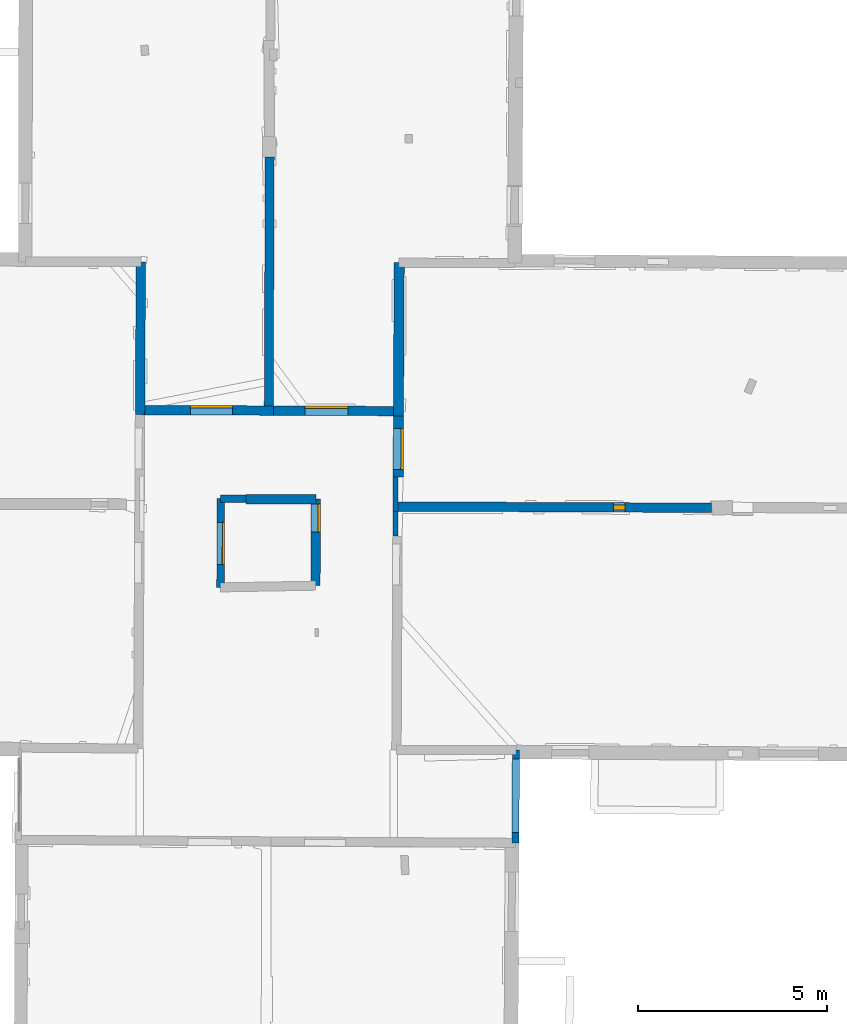
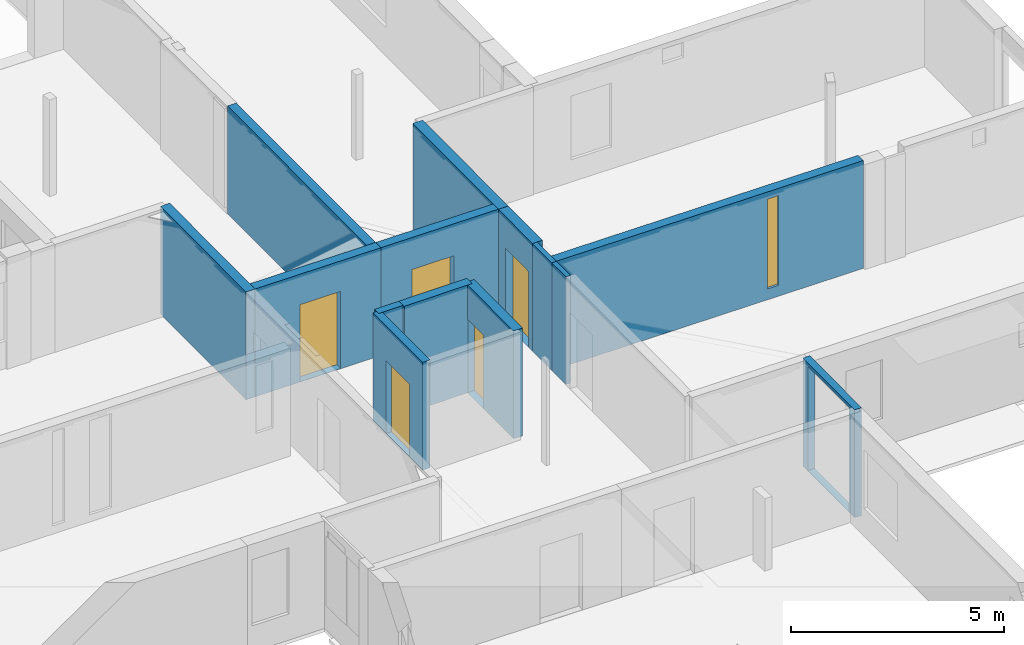
# One storey, part 10 of 17: 14 walls, 5 doors, 1 window, 7 openings.
"""IFC2X3 building model written with IfcOpenShell, lengths in metres."""

from ifc_helpers import new_model, entity, si_unit, converted_unit, derived_unit, direction, frame, frame_2d, origin, origin_2d_with_axis, place, context, subcontext, project, spatial, polyline, rectangle, outline, extrude, clip, halfspace, source, transform, mapped, material, layer, layer_set, layer_usage, type_object, type_shapes, element, fill, save


model = new_model("IFC2X3")

# Units and contexts
model_context = context("Model", 3, precision=1e-05, world=origin(), true_north=direction((0.0, 1.0)))
body_context = subcontext(model_context, "Body", "Model", "MODEL_VIEW")
ifc_project = project(units=[si_unit("LENGTHUNIT", "METRE"), si_unit("AREAUNIT", "SQUARE_METRE"), si_unit("VOLUMEUNIT", "CUBIC_METRE"), converted_unit("PLANEANGLEUNIT", "DEGREE", entity("IfcRatioMeasure", 0.0174532925199433), si_unit("PLANEANGLEUNIT", "RADIAN"), dimensions=[0, 0, 0, 0, 0, 0, 0]), si_unit("MASSUNIT", "GRAM", prefix="KILO"), derived_unit("MASSDENSITYUNIT", [(si_unit("MASSUNIT", "GRAM", prefix="KILO"), 1), (si_unit("LENGTHUNIT", "METRE"), -3)]), derived_unit("MOMENTOFINERTIAUNIT", [(si_unit("LENGTHUNIT", "METRE"), 4)]), si_unit("TIMEUNIT", "SECOND"), si_unit("FREQUENCYUNIT", "HERTZ"), si_unit("THERMODYNAMICTEMPERATUREUNIT", "DEGREE_CELSIUS"), derived_unit("THERMALTRANSMITTANCEUNIT", [(si_unit("MASSUNIT", "GRAM", prefix="KILO"), 1), (si_unit("THERMODYNAMICTEMPERATUREUNIT", "KELVIN"), -1), (si_unit("TIMEUNIT", "SECOND"), -3)]), derived_unit("VOLUMETRICFLOWRATEUNIT", [(si_unit("LENGTHUNIT", "METRE"), 3), (si_unit("TIMEUNIT", "SECOND"), -1)]), si_unit("ELECTRICCURRENTUNIT", "AMPERE"), si_unit("ELECTRICVOLTAGEUNIT", "VOLT"), si_unit("POWERUNIT", "WATT"), si_unit("FORCEUNIT", "NEWTON", prefix="KILO"), si_unit("ILLUMINANCEUNIT", "LUX"), si_unit("LUMINOUSFLUXUNIT", "LUMEN"), si_unit("LUMINOUSINTENSITYUNIT", "CANDELA"), derived_unit("USERDEFINED", [(si_unit("MASSUNIT", "GRAM", prefix="KILO"), -1), (si_unit("LENGTHUNIT", "METRE"), -2), (si_unit("TIMEUNIT", "SECOND"), 3), (si_unit("LUMINOUSFLUXUNIT", "LUMEN"), 1)]), derived_unit("LINEARVELOCITYUNIT", [(si_unit("LENGTHUNIT", "METRE"), 1), (si_unit("TIMEUNIT", "SECOND"), -1)]), si_unit("PRESSUREUNIT", "PASCAL"), derived_unit("USERDEFINED", [(si_unit("LENGTHUNIT", "METRE"), -2), (si_unit("MASSUNIT", "GRAM", prefix="KILO"), 1), (si_unit("TIMEUNIT", "SECOND"), -2)]), derived_unit("LINEARFORCEUNIT", [(si_unit("MASSUNIT", "GRAM", prefix="KILO"), 1), (si_unit("LENGTHUNIT", "METRE"), 1), (si_unit("TIMEUNIT", "SECOND"), -2), (si_unit("LENGTHUNIT", "METRE"), -1)]), derived_unit("PLANARFORCEUNIT", [(si_unit("MASSUNIT", "GRAM", prefix="KILO"), 1), (si_unit("LENGTHUNIT", "METRE"), 1), (si_unit("TIMEUNIT", "SECOND"), -2), (si_unit("LENGTHUNIT", "METRE"), -2)])], contexts=[model_context])

# Site, building, storey
placement = place(None, origin())
site = spatial("IfcSite", under=ifc_project, at=placement, CompositionType="ELEMENT")
building = spatial("IfcBuilding", under=site, at=placement, CompositionType="ELEMENT")
storey_placement = place(placement, frame((0.0, 0.0, 12.0782108306885)))
storey = spatial("IfcBuildingStorey", under=building, at=storey_placement, Name="Level 5", CompositionType="ELEMENT", Elevation=12.0782108306885)

# Wall, opening, door
ifc_material_1 = material(Name="Default wall")
ifc_layer_1 = layer(ifc_material_1, 0.25)
ifc_layer_set_1 = layer_set([ifc_layer_1], Name="wall_thickness_0.2500")
ifc_layer_usage_1 = layer_usage(ifc_layer_set_1, "AXIS2", "POSITIVE", -0.125)
wall_type_1 = type_object("IfcWallType", Name="wall_thickness_0.2500", PredefinedType="STANDARD", material=ifc_layer_set_1)
wall_1_placement = place(storey_placement, frame((2.9732673349329, 60.1694172213467, 0.0), z_axis=(0.0, 0.0, 1.0), x_axis=(0.999991078854273, -0.00422400424551604, 0.0)))
wall_1 = element("IfcWallStandardCase", 1, at=wall_1_placement, inside=storey, type_object=wall_type_1, material=ifc_layer_usage_1, Name="Wall:252", ObjectType="Wall", context=body_context, shape_type="Clipping", body=[
    clip(clip(extrude(outline(polyline([(3.52570150487162, -0.125), (3.52570150487162, 0.125), (0.0, 0.125), (0.0, -0.125), (3.52570150487162, -0.125)])), origin(), (0.0, 0.0, 1.0), 3.09134044647217), halfspace(frame((21.6645418552215, -2.57535797375986, 9.01350348246577), z_axis=(0.000828137503824083, 0.389454305620105, 0.921045415830423), x_axis=(-0.999992003356814, 0.00392608366811369, -0.000760979274747706)), False)), halfspace(frame((-4.30223903086172, 15.6563531810917, 5.79573318480268), z_axis=(-0.389900704445387, -0.000232514676882885, 0.920856876289642), x_axis=(0.920854522577645, -0.00165731940970147, 0.389902810378011)), False)),
])
opening_1_placement = place(wall_1_placement, frame((1.34075493354691, -0.125, 0.00578975677490234)))
opening_1 = element("IfcOpeningElement", 2, at=opening_1_placement, cuts=wall_1, Name="Opening : 1100 x 2215 : 226", ObjectType="Opening", context=body_context, shape_type="SweptSolid", body=[
    extrude(rectangle(XDim=1.1, YDim=2.215, at=frame_2d((1.1075, 0.55), x_axis=(0.0, 1.0))), frame((0.0, 0.0, 0.0), z_axis=(0.0, 1.0, 0.0), x_axis=(0.0, 0.0, 1.0)), (0.0, 0.0, 1.0), 0.25),
])
ifc_material_2 = material(Name="Door Panel")
door_style_1 = type_object("IfcDoorStyle", Name="Door : 1100 x 2215mm", ConstructionType="NOTDEFINED", OperationType="SINGLE_SWING_RIGHT", ParameterTakesPrecedence=False, Sizeable=False, material=ifc_material_2)
shared_shape_1 = source(origin(), body_context, "Body", "SweptSolid", [
    extrude(rectangle(XDim=0.0625, YDim=1.1, at=origin_2d_with_axis()), frame((0.55, 0.21875, 0.0), z_axis=(0.0, 0.0, 1.0), x_axis=(0.0, 1.0, 0.0)), (0.0, 0.0, 1.0), 2.215),
])
type_shapes(door_style_1, [shared_shape_1])
door_1_placement = place(opening_1_placement, origin())
door_1 = element("IfcDoor", 3, at=door_1_placement, inside=storey, type_object=door_style_1, Name="Door : 1100 x 2215mm : 38", ObjectType="Door : 1100 x 2215mm", OverallHeight=2.215, OverallWidth=1.1, context=body_context, shape_type="MappedRepresentation", body=[
    mapped(shared_shape_1, transform((0.0, 0.0, 0.0), scale=1.0)),
])
fill(opening_1, door_1)

wall_2_placement = place(storey_placement, frame((6.4989373865076, 60.1545246432217, 0.0), z_axis=(0.0, 0.0, 1.0), x_axis=(0.999991078140899, -0.0042241731265633, 0.0)))
wall_2 = element("IfcWallStandardCase", 4, at=wall_2_placement, inside=storey, type_object=wall_type_1, material=ifc_layer_usage_1, Name="Wall:253", ObjectType="Wall", context=body_context, shape_type="Clipping", body=[
    clip(clip(extrude(outline(polyline([(3.31243752352933, -0.125), (3.31243752352933, 0.125), (0.0, 0.125), (0.0, -0.125), (3.31243752352933, -0.125)])), origin(), (0.0, 0.0, 1.0), 3.09134044647217), halfspace(frame((18.1388407852826, -2.57535491042614, 9.01350348246577), z_axis=(0.000828071731786291, 0.389454305759958, 0.921045415830423), x_axis=(-0.999992004019847, 0.00392591478691017, -0.000760979274747706)), False)), halfspace(frame((6.24537303460496, 17.1086275764733, 6.35864093399329), z_axis=(0.390500039958128, -0.000254261316809501, 0.920602875372374), x_axis=(-0.680866467789572, -0.673140016301975, 0.288623234499112)), False)),
])
opening_2_placement = place(wall_2_placement, frame((0.845053493044792, -0.125, 0.00578975677490234)))
opening_2 = element("IfcOpeningElement", 5, at=opening_2_placement, cuts=wall_2, Name="Opening : 1135 x 2170 : 227", ObjectType="Opening", context=body_context, shape_type="SweptSolid", body=[
    extrude(rectangle(XDim=1.135, YDim=2.17, at=frame_2d((1.085, 0.5675), x_axis=(0.0, 1.0))), frame((0.0, 0.0, 0.0), z_axis=(0.0, 1.0, 0.0), x_axis=(0.0, 0.0, 1.0)), (0.0, 0.0, 1.0), 0.25),
])
door_style_2 = type_object("IfcDoorStyle", Name="Door : 1135 x 2170mm", ConstructionType="NOTDEFINED", OperationType="SINGLE_SWING_RIGHT", ParameterTakesPrecedence=False, Sizeable=False, material=ifc_material_2)
shared_shape_2 = source(origin(), body_context, "Body", "SweptSolid", [
    extrude(rectangle(XDim=0.0625, YDim=1.135, at=origin_2d_with_axis()), frame((0.5675, 0.21875, 0.0), z_axis=(0.0, 0.0, 1.0), x_axis=(0.0, 1.0, 0.0)), (0.0, 0.0, 1.0), 2.17),
])
type_shapes(door_style_2, [shared_shape_2])
door_2_placement = place(opening_2_placement, origin())
door_2 = element("IfcDoor", 6, at=door_2_placement, inside=storey, type_object=door_style_2, Name="Door : 1135 x 2170mm : 39", ObjectType="Door : 1135 x 2170mm", OverallHeight=2.17, OverallWidth=1.135, context=body_context, shape_type="MappedRepresentation", body=[
    mapped(shared_shape_2, transform((0.0, 0.0, 0.0), scale=1.0)),
])
fill(opening_2, door_2)

# Wall, opening, window
wall_3_placement = place(storey_placement, frame((9.73171064603028, 57.616053512142, 0.0), z_axis=(0.0, 0.0, 1.0), x_axis=(0.999991816075073, -0.00404571166512474, 0.0)))
wall_3 = element("IfcWallStandardCase", 7, at=wall_3_placement, inside=storey, type_object=wall_type_1, material=ifc_layer_usage_1, Name="Wall:260", ObjectType="Wall", context=body_context, shape_type="Clipping", body=[
    clip(clip(extrude(outline(polyline([(8.36634234952258, -0.125), (8.36634234952258, 0.125), (0.0, 0.125), (0.0, -0.125), (8.36634234952258, -0.125)])), origin(), (0.0, 0.0, 1.0), 3.09134044647217), halfspace(frame((14.8953641658864, -0.0532204931752561, 9.01350348246577), z_axis=(0.000897574897068893, 0.389454151777931, 0.921045415830423), x_axis=(-0.999991287464978, 0.00410437628379763, -0.000760979274747706)), False)), halfspace(frame((3.00540946690516, 19.6328842240395, 6.35864093399329), z_axis=(0.390499988363369, -0.000323951116077735, 0.920602875372374), x_axis=(-0.68098658752467, -0.673018496119368, 0.288623234499112)), False)),
])
opening_3_placement = place(wall_3_placement, frame((5.77032811993926, -0.125, 0.310789108276367)))
opening_3 = element("IfcOpeningElement", 8, at=opening_3_placement, cuts=wall_3, Name="Opening : 305 x 2575 : 228", ObjectType="Opening", context=body_context, shape_type="SweptSolid", body=[
    extrude(rectangle(XDim=0.305, YDim=2.575, at=frame_2d((1.2875, 0.1525), x_axis=(0.0, 1.0))), frame((0.0, 0.0, 0.0), z_axis=(0.0, 1.0, 0.0), x_axis=(0.0, 0.0, 1.0)), (0.0, 0.0, 1.0), 0.25),
])
ifc_material_3 = material(Name="Window Default")
window_style = type_object("IfcWindowStyle", Name="Window : 305 x 2575mm", ConstructionType="NOTDEFINED", OperationType="NOTDEFINED", ParameterTakesPrecedence=False, Sizeable=False, material=ifc_material_3)
shared_shape_3 = source(origin(), body_context, "Body", "SweptSolid", [
    extrude(rectangle(XDim=0.125, YDim=0.305, at=origin_2d_with_axis()), frame((0.1525, 0.125, 0.0), z_axis=(0.0, 0.0, 1.0), x_axis=(0.0, 1.0, 0.0)), (0.0, 0.0, 1.0), 2.575),
])
type_shapes(window_style, [shared_shape_3])
window_placement = place(opening_3_placement, origin())
window = element("IfcWindow", 9, at=window_placement, inside=storey, type_object=window_style, Name="Window : 305 x 2575mm : 123", ObjectType="Window : 305 x 2575mm", OverallHeight=2.575, OverallWidth=0.305, context=body_context, shape_type="MappedRepresentation", body=[
    mapped(shared_shape_3, transform((0.0, 0.0, 0.0), scale=1.0)),
])
fill(opening_3, window)

# Walls
wall_4_placement = place(storey_placement, frame((2.99464268628783, 64.0884731860502, 0.0), z_axis=(0.0, 0.0, 1.0), x_axis=(-0.00545393374022704, -0.999985127192778, 0.0)))
element("IfcWallStandardCase", 10, at=wall_4_placement, inside=storey, type_object=wall_type_1, material=ifc_layer_usage_1, Name="Wall:292", ObjectType="Wall", context=body_context, shape_type="Clipping", body=[
    clip(clip(extrude(outline(polyline([(4.04411608607963, -0.125), (4.04411608607963, 0.125), (0.0, 0.125), (0.0, -0.125), (4.04411608607963, -0.125)])), origin(), (0.0, 0.0, 1.0), 3.09134044647217), halfspace(frame((6.46782411694884, 21.6676922519037, 9.01350348246577), z_axis=(-0.389455029606745, 0.000349130022532686, 0.921045415830423), x_axis=(-0.00269614687174498, -0.999996075843595, -0.000760979274747706)), False)), halfspace(frame((-11.731935570205, -4.32149297098546, 5.79573318480268), z_axis=(0.00071207040132309, -0.389900123551952, 0.920856876289642), x_axis=(0.00052471897230797, 0.920855864470292, 0.389902810378011)), False)),
])
wall_5_placement = place(storey_placement, frame((5.7749620022934, 57.8037623513929, 0.0), z_axis=(0.0, 0.0, 1.0), x_axis=(0.999984060929774, 0.00564605051327349, 0.0)))
element("IfcWallStandardCase", 11, at=wall_5_placement, inside=storey, type_object=wall_type_1, material=ifc_layer_usage_1, Name="Wall:315", ObjectType="Wall", context=body_context, shape_type="Clipping", body=[
    clip(clip(extrude(outline(polyline([(1.85125345287647, -0.125), (1.85125345287647, 0.125), (0.0, 0.125), (0.0, -0.125), (1.85125345287647, -0.125)])), origin(), (0.0, 0.0, 1.0), 3.09134044647217), halfspace(frame((18.8497745715502, -0.407624521986581, 9.01350348246577), z_axis=(0.00467198665138822, 0.389427162019411, 0.921045415830423), x_axis=(-0.999904544532518, 0.0137957505689299, -0.000760979274747706)), False)), halfspace(frame((7.15116915220887, 19.3927889313616, 6.35864093399329), z_axis=(0.39047850884874, -0.00410852569442614, 0.920602875372374), x_axis=(-0.687477265591048, -0.666387003026564, 0.288623234499112)), False)),
])

# Wall, opening, door
wall_6_placement = place(storey_placement, frame((7.62618536055974, 57.8142134133595, 0.0), z_axis=(0.0, 0.0, 1.0), x_axis=(-0.00487799784660682, -0.999988102497729, 0.0)))
wall_6 = element("IfcWallStandardCase", 12, at=wall_6_placement, inside=storey, type_object=wall_type_1, material=ifc_layer_usage_1, Name="Wall:324", ObjectType="Wall", context=body_context, shape_type="Clipping", body=[
    clip(clip(extrude(outline(polyline([(2.29239711632919, -0.125), (2.29239711632919, 0.125), (0.0, 0.125), (0.0, -0.125), (2.29239711632919, -0.125)])), origin(), (0.0, 0.0, 1.0), 3.09134044647217), halfspace(frame((0.106395693502195, -20.3790788361604, 9.01748660239985), z_axis=(0.391124742861679, -0.00198013404353166, 0.920335544565435), x_axis=(0.00327203185553808, 0.999994357348396, 0.000760972341273259)), False)), halfspace(frame((-19.4474920137023, 5.09553494502933, 6.35864093399329), z_axis=(-1.05994736626733e-06, 0.390500122733647, 0.920602875372374), x_axis=(0.673585044333981, -0.680426202138674, 0.288623234499112)), False)),
])
opening_4_placement = place(wall_6_placement, frame((0.126325212350073, -0.125, 0.00578975677490234)))
opening_4 = element("IfcOpeningElement", 13, at=opening_4_placement, cuts=wall_6, Name="Opening : 740 x 2105 : 268", ObjectType="Opening", context=body_context, shape_type="SweptSolid", body=[
    extrude(rectangle(XDim=0.74, YDim=2.105, at=frame_2d((1.0525, 0.37), x_axis=(0.0, 1.0))), frame((0.0, 0.0, 0.0), z_axis=(0.0, 1.0, 0.0), x_axis=(0.0, 0.0, 1.0)), (0.0, 0.0, 1.0), 0.25),
])
door_style_3 = type_object("IfcDoorStyle", Name="Door : 740 x 2105mm", ConstructionType="NOTDEFINED", OperationType="SINGLE_SWING_RIGHT", ParameterTakesPrecedence=False, Sizeable=False, material=ifc_material_2)
shared_shape_4 = source(origin(), body_context, "Body", "SweptSolid", [
    extrude(rectangle(XDim=0.0625, YDim=0.74, at=origin_2d_with_axis()), frame((0.37, 0.21875, 0.0), z_axis=(0.0, 0.0, 1.0), x_axis=(0.0, 1.0, 0.0)), (0.0, 0.0, 1.0), 2.105),
])
type_shapes(door_style_3, [shared_shape_4])
door_3_placement = place(opening_4_placement, origin())
door_3 = element("IfcDoor", 14, at=door_3_placement, inside=storey, type_object=door_style_3, Name="Door : 740 x 2105mm : 52", ObjectType="Door : 740 x 2105mm", OverallHeight=2.105, OverallWidth=0.74, context=body_context, shape_type="MappedRepresentation", body=[
    mapped(shared_shape_4, transform((0.0, 0.0, 0.0), scale=1.0)),
])
fill(opening_4, door_3)

ifc_layer_2 = layer(ifc_material_1, 0.2)
ifc_layer_set_2 = layer_set([ifc_layer_2], Name="wall_thickness_0.2000")
ifc_layer_usage_2 = layer_usage(ifc_layer_set_2, "AXIS2", "POSITIVE", -0.1)
wall_type_2 = type_object("IfcWallType", Name="wall_thickness_0.2000", PredefinedType="STANDARD", material=ifc_layer_set_2)
wall_7_placement = place(storey_placement, frame((5.10834911673756, 57.8231719392913, 0.0), z_axis=(0.0, 0.0, 1.0), x_axis=(-0.00245738744091306, -0.999996980618924, 0.0)))
wall_7 = element("IfcWallStandardCase", 15, at=wall_7_placement, inside=storey, type_object=wall_type_2, material=ifc_layer_usage_2, Name="Wall:274", ObjectType="Wall", context=body_context, shape_type="Clipping", body=[
    clip(clip(extrude(outline(polyline([(2.34674780838217, -0.1), (2.34674780838217, 0.1), (0.0, 0.1), (0.0, -0.1), (2.34674780838217, -0.1)])), origin(), (0.0, 0.0, 1.0), 3.09134044647217), halfspace(frame((0.0598364755579056, -17.8614260192135, 9.01748660239985), z_axis=(0.391118803815158, -0.00292689453932598, 0.920335544565435), x_axis=(0.00569263352460047, 0.99998350728632, 0.000760972341273259)), False)), halfspace(frame((-18.004920671496, -6.41541436597232, 5.79573318480268), z_axis=(-0.000456294397486972, -0.389900506777699, 0.920856876289642), x_axis=(0.00328412234082108, 0.920850157734568, 0.389902810378011)), False)),
])
opening_5_placement = place(wall_7_placement, frame((0.623910894476473, -0.1, 0.00578975677490234)))
opening_5 = element("IfcOpeningElement", 16, at=opening_5_placement, cuts=wall_7, Name="Opening : 1115 x 2085 : 237", ObjectType="Opening", context=body_context, shape_type="SweptSolid", body=[
    extrude(rectangle(XDim=1.115, YDim=2.085, at=frame_2d((1.0425, 0.5575), x_axis=(0.0, 1.0))), frame((0.0, 0.0, 0.0), z_axis=(0.0, 1.0, 0.0), x_axis=(0.0, 0.0, 1.0)), (0.0, 0.0, 1.0), 0.2),
])
door_style_4 = type_object("IfcDoorStyle", Name="Door : 1115 x 2085mm", ConstructionType="NOTDEFINED", OperationType="SINGLE_SWING_RIGHT", ParameterTakesPrecedence=False, Sizeable=False, material=ifc_material_2)
shared_shape_5 = source(origin(), body_context, "Body", "SweptSolid", [
    extrude(rectangle(XDim=0.05, YDim=1.115, at=origin_2d_with_axis()), frame((0.5575, 0.175, 0.0), z_axis=(0.0, 0.0, 1.0), x_axis=(0.0, 1.0, 0.0)), (0.0, 0.0, 1.0), 2.085),
])
type_shapes(door_style_4, [shared_shape_5])
door_4_placement = place(opening_5_placement, origin())
door_4 = element("IfcDoor", 17, at=door_4_placement, inside=storey, type_object=door_style_4, Name="Door : 1115 x 2085mm : 43", ObjectType="Door : 1115 x 2085mm", OverallHeight=2.085, OverallWidth=1.115, context=body_context, shape_type="MappedRepresentation", body=[
    mapped(shared_shape_5, transform((0.0, 0.0, 0.0), scale=1.0)),
])
fill(opening_5, door_4)

# Walls
wall_8_placement = place(storey_placement, frame((5.10834929641943, 57.8231731360919, 0.0), z_axis=(0.0, 0.0, 1.0), x_axis=(0.999988611499875, 0.0047725119749978, 0.0)))
element("IfcWallStandardCase", 18, at=wall_8_placement, inside=storey, type_object=wall_type_2, material=ifc_layer_usage_2, Name="Wall:309", ObjectType="Wall", context=body_context, shape_type="Clipping", body=[
    clip(clip(extrude(outline(polyline([(0.666621170611671, -0.1), (0.666621170611671, 0.1), (0.0, 0.1), (0.0, -0.1), (0.666621170611671, -0.1)])), origin(), (0.0, 0.0, 1.0), 3.09134044647217), halfspace(frame((19.5166359359895, -0.413750120844335, 9.01350348246577), z_axis=(0.004331800651632, 0.389431094650746, 0.921045415830423), x_axis=(-0.99991621430595, 0.012922278382749, -0.000760979274747706)), False)), halfspace(frame((-6.28507387753787, 18.0508314319101, 5.79573318480268), z_axis=(-0.389887017489234, 0.00327520738788472, 0.920856876289642), x_axis=(0.920802346882913, -0.00994165148498868, 0.38990281037801)), False)),
])
ifc_layer_3 = layer(ifc_material_1, 0.239999994635582)
ifc_layer_set_3 = layer_set([ifc_layer_3], Name="wall_thickness_0.2400")
ifc_layer_usage_3 = layer_usage(ifc_layer_set_3, "AXIS2", "POSITIVE", -0.119999997317791)
wall_type_3 = type_object("IfcWallType", Name="wall_thickness_0.2400", PredefinedType="STANDARD", material=ifc_layer_set_3)
wall_9_placement = place(storey_placement, frame((6.40479595041977, 66.8597538538802, 0.0), z_axis=(0.0, 0.0, 1.0), x_axis=(-0.00385656879219763, -0.999992563410924, 0.0)))
element("IfcWallStandardCase", 19, at=wall_9_placement, inside=storey, type_object=wall_type_3, material=ifc_layer_usage_3, Name="Wall:368", ObjectType="Wall", context=body_context, shape_type="Clipping", body=[
    clip(clip(extrude(outline(polyline([(6.70478084824884, -0.119999997317791), (6.70478084824884, 0.119999997317791), (0.0, 0.119999997317791), (0.0, -0.119999997317791), (6.70478084824884, -0.119999997317791)])), origin(), (0.0, 0.0, 1.0), 3.09134044647217), halfspace(frame((9.28683899092201, 18.2578927540611, 9.01350348246577), z_axis=(-0.389453975040237, 0.000971237932822498, 0.921045415830423), x_axis=(-0.00429351891095415, -0.999990493257763, -0.000760979274747706)), False)), halfspace(frame((-10.4015142918871, 6.37166178321619, 6.35864093399329), z_axis=(0.000397811976171796, 0.390499920104664, 0.920602875372374), x_axis=(0.672889679316117, -0.681113872988302, 0.288623234499112)), False)),
])
ifc_layer_4 = layer(ifc_material_1, 0.129999995231628)
ifc_layer_set_4 = layer_set([ifc_layer_4], Name="wall_thickness_0.1300")
ifc_layer_usage_4 = layer_usage(ifc_layer_set_4, "AXIS2", "POSITIVE", -0.0649999976158142)
wall_type_4 = type_object("IfcWallType", Name="wall_thickness_0.1300", PredefinedType="STANDARD", material=ifc_layer_set_4)
wall_10_placement = place(storey_placement, frame((9.73261032859246, 58.396319084667, 0.0), z_axis=(0.0, 0.0, 1.0), x_axis=(-0.00115460712722947, -0.999999333440969, 0.0)))
element("IfcWallStandardCase", 20, at=wall_10_placement, inside=storey, type_object=wall_type_4, material=ifc_layer_usage_4, Name="Wall:279", ObjectType="Wall", context=body_context, shape_type="Clipping", body=[
    clip(clip(extrude(outline(polyline([(0.905266411518971, -0.0649999976158142), (0.905266411518971, 0.0649999976158142), (0.0, 0.0649999976158142), (0.0, -0.0649999976158142), (0.905266411518971, -0.0649999976158142)])), origin(), (0.0, 0.0, 1.0), 3.09134044647217), halfspace(frame((0.876550517479008, 14.8951492659832, 9.01350348246577), z_axis=(-0.389449929154577, 0.00202352644116146, 0.921045415830423), x_axis=(-0.00699544523199617, -0.999975242021796, -0.000760979274747706)), False)), halfspace(frame((-18.8438471084423, 3.06215897795666, 6.35864093399329), z_axis=(0.00145292868745961, 0.390497419779371, 0.920602875372374), x_axis=(0.671046875380889, -0.682929512869971, 0.288623234499112)), False)),
])
wall_11_placement = place(storey_placement, frame((9.73156510154168, 57.4910532765616, 0.0), z_axis=(0.0, 0.0, 1.0), x_axis=(-0.00115431377014093, -0.999999333779638, 0.0)))
element("IfcWallStandardCase", 21, at=wall_11_placement, inside=storey, type_object=wall_type_4, material=ifc_layer_usage_4, Name="Wall:280", ObjectType="Wall", context=body_context, shape_type="Clipping", body=[
    clip(clip(extrude(outline(polyline([(0.660946332669889, -0.0649999976158142), (0.660946332669889, 0.0649999976158142), (0.0, 0.0649999976158142), (0.0, -0.0649999976158142), (0.660946332669889, -0.0649999976158142)])), origin(), (0.0, 0.0, 1.0), 3.09134044647217), halfspace(frame((-0.290220161814068, -22.4850851001201, 9.01748660239985), z_axis=(0.391114657789396, -0.00343654939262517, 0.920335544565435), x_axis=(0.00699568271920818, 0.999975240365674, 0.000760972341273259)), False)), halfspace(frame((-19.7491126216538, 3.06216477150283, 6.35864093399329), z_axis=(0.00145304324272203, 0.390497419353127, 0.920602875372374), x_axis=(0.671046675038513, -0.682929709726431, 0.288623234499112)), False)),
])
ifc_layer_5 = layer(ifc_material_1, 0.270000010728836)
ifc_layer_set_5 = layer_set([ifc_layer_5], Name="wall_thickness_0.2700")
ifc_layer_usage_5 = layer_usage(ifc_layer_set_5, "AXIS2", "POSITIVE", -0.135000005364418)
wall_type_5 = type_object("IfcWallType", Name="wall_thickness_0.2700", PredefinedType="STANDARD", material=ifc_layer_set_5)
wall_12_placement = place(storey_placement, frame((9.83063989355751, 64.0673909136075, 0.0), z_axis=(0.0, 0.0, 1.0), x_axis=(-0.00491346677148143, -0.999987928849286, 0.0)))
element("IfcWallStandardCase", 22, at=wall_12_placement, inside=storey, type_object=wall_type_5, material=ifc_layer_usage_5, Name="Wall:294", ObjectType="Wall", context=body_context, shape_type="Clipping", body=[
    clip(clip(extrude(outline(polyline([(4.05190590579577, -0.135000005364418), (4.05190590579577, 0.135000005364418), (0.0, 0.135000005364418), (0.0, -0.135000005364418), (4.05190590579577, -0.135000005364418)])), origin(), (0.0, 0.0, 1.0), 3.09134044647217), halfspace(frame((6.49204042831947, 14.8281751191073, 9.01350348246577), z_axis=(-0.389454784028652, 0.000559620371205161, 0.921045415830423), x_axis=(-0.00323661856758435, -0.99999447259012, -0.000760979274747706)), False)), halfspace(frame((-13.1837392054841, 2.92114200909315, 6.35864093399329), z_axis=(-1.4910732870336e-05, 0.390500122450412, 0.920602875372374), x_axis=(0.673609178185342, -0.680402310087009, 0.288623234499112)), False)),
])

# Wall, opening, door
wall_13_placement = place(storey_placement, frame((9.81073098852821, 60.0155339189786, 0.0), z_axis=(0.0, 0.0, 1.0), x_axis=(-0.00491372281916375, -0.999987927591157, 0.0)))
wall_13 = element("IfcWallStandardCase", 23, at=wall_13_placement, inside=storey, type_object=wall_type_5, material=ifc_layer_usage_5, Name="Wall:295", ObjectType="Wall", context=body_context, shape_type="Clipping", body=[
    clip(clip(extrude(outline(polyline([(1.61982393750105, -0.135000005364418), (1.61982393750105, 0.135000005364418), (0.0, 0.135000005364418), (0.0, -0.135000005364418), (1.61982393750105, -0.135000005364418)])), origin(), (0.0, 0.0, 1.0), 3.09134044647217), halfspace(frame((2.44013072575792, 14.8281757439052, 9.01350348246577), z_axis=(-0.38945478417193, 0.000559520651006546, 0.921045415830423), x_axis=(-0.00323636251822629, -0.999994473418825, -0.000760979274747706)), False)), halfspace(frame((-17.2356458592399, 2.9211375958928, 6.35864093399329), z_axis=(-1.50107207286434e-05, 0.390500122446582, 0.920602875372374), x_axis=(0.673609352402858, -0.680402137608836, 0.288623234499112)), False)),
])
opening_6_placement = place(wall_13_placement, frame((0.330684907149585, -0.135000005364418, 0.00578975677490234)))
opening_6 = element("IfcOpeningElement", 24, at=opening_6_placement, cuts=wall_13, Name="Opening : 1090 x 2170 : 248", ObjectType="Opening", context=body_context, shape_type="SweptSolid", body=[
    extrude(rectangle(XDim=1.09, YDim=2.17, at=frame_2d((1.085, 0.545), x_axis=(0.0, 1.0))), frame((0.0, 0.0, 0.0), z_axis=(0.0, 1.0, 0.0), x_axis=(0.0, 0.0, 1.0)), (0.0, 0.0, 1.0), 0.270000010728836),
])
door_style_5 = type_object("IfcDoorStyle", Name="Door : 1090 x 2170mm", ConstructionType="NOTDEFINED", OperationType="SINGLE_SWING_RIGHT", ParameterTakesPrecedence=False, Sizeable=False, material=ifc_material_2)
shared_shape_6 = source(origin(), body_context, "Body", "SweptSolid", [
    extrude(rectangle(XDim=0.067500002682209, YDim=1.09, at=origin_2d_with_axis()), frame((0.545, 0.236250009387732, 0.0), z_axis=(0.0, 0.0, 1.0), x_axis=(0.0, 1.0, 0.0)), (0.0, 0.0, 1.0), 2.17),
])
type_shapes(door_style_5, [shared_shape_6])
door_5_placement = place(opening_6_placement, origin())
door_5 = element("IfcDoor", 25, at=door_5_placement, inside=storey, type_object=door_style_5, Name="Door : 1090 x 2170mm : 48", ObjectType="Door : 1090 x 2170mm", OverallHeight=2.17, OverallWidth=1.09, context=body_context, shape_type="MappedRepresentation", body=[
    mapped(shared_shape_6, transform((0.0, 0.0, 0.0), scale=1.0)),
])
fill(opening_6, door_5)

# Wall, opening
ifc_layer_6 = layer(ifc_material_1, 0.189999997615814)
ifc_layer_set_6 = layer_set([ifc_layer_6], Name="wall_thickness_0.1900")
ifc_layer_usage_6 = layer_usage(ifc_layer_set_6, "AXIS2", "POSITIVE", -0.0949999988079071)
wall_type_6 = type_object("IfcWallType", Name="wall_thickness_0.1900", PredefinedType="STANDARD", material=ifc_layer_set_6)
wall_14_placement = place(storey_placement, frame((12.9181666025387, 51.1705906929854, 0.0), z_axis=(0.0, 0.0, 1.0), x_axis=(-0.0048715237279633, -0.999988134057884, 0.0)))
wall_14 = element("IfcWallStandardCase", 26, at=wall_14_placement, inside=storey, type_object=wall_type_6, material=ifc_layer_usage_6, Name="Wall:318", ObjectType="Wall", context=body_context, shape_type="Clipping", body=[
    clip(extrude(outline(polyline([(2.45293666866038, -0.0949999988079071), (2.45293666866038, 0.0949999988079071), (0.0, 0.0949999988079071), (0.0, -0.0949999988079071), (2.45293666866038, -0.0949999988079071)])), origin(), (0.0, 0.0, 1.0), 3.09134044647217), halfspace(frame((-26.0652228991481, -0.22862216156865, 6.35864093399329), z_axis=(1.46822679768016e-06, 0.390500122732326, 0.920602875372374), x_axis=(0.673580639107562, -0.680430563045723, 0.288623234499112)), False)),
])
opening_7_placement = place(wall_14_placement, frame((0.238604546209188, -0.0949999988079071, 0.00578975677490234)))
element("IfcOpeningElement", 27, at=opening_7_placement, cuts=wall_14, Name="Opening : 1940 x 2990 : 259", ObjectType="Opening", context=body_context, shape_type="SweptSolid", body=[
    extrude(rectangle(XDim=1.94, YDim=2.99, at=frame_2d((1.495, 0.97), x_axis=(0.0, 1.0))), frame((0.0, 0.0, 0.0), z_axis=(0.0, 1.0, 0.0), x_axis=(0.0, 0.0, 1.0)), (0.0, 0.0, 1.0), 0.189999997615814),
])

save(model, "model.ifc")
